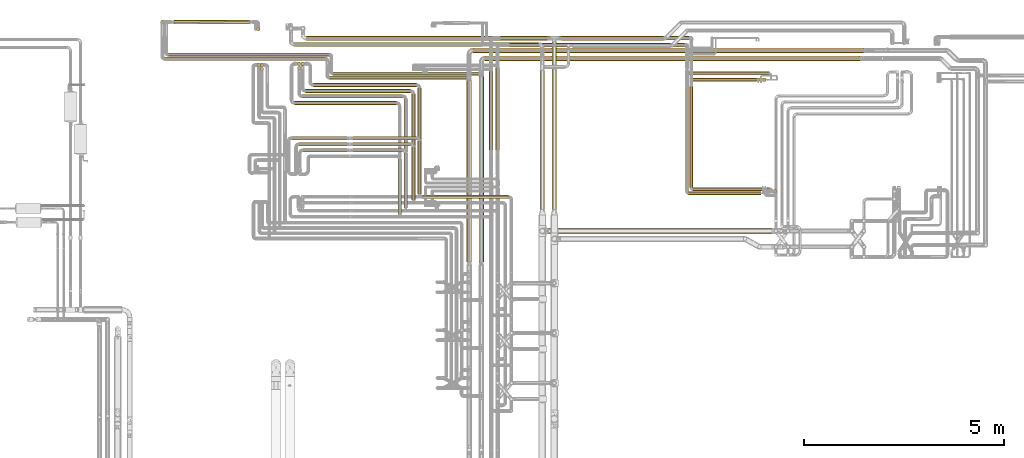
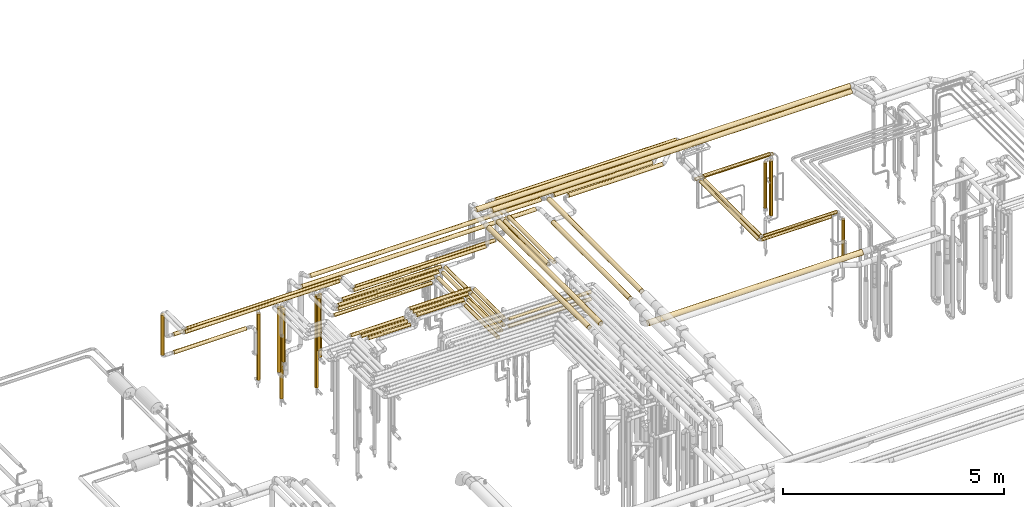
# One storey, part 6 of 824: 57 coverings.
"""IFC2X3 building model written with IfcOpenShell, lengths in millimetres."""

import ifcopenshell
import ifcopenshell.guid

model = None  # the IFC model being written
_history = None  # IfcOwnerHistory: only IFC2X3 demands one
_inside = {}  # id of a spatial element -> (the spatial element, [elements in it])
_under = {}  # id of a project, library or spatial element -> (it, [spatial elements below it])
_declared = {}  # id of a project -> (the project, [libraries it declares])
_typed = {}  # id of a type object -> (the type object, [elements of that type])
_made_of = {}  # id of a material, layer set ... -> (it, [elements and type objects made of it])


def new_model(schema):
    """Start an empty IFC model of exactly this schema.

    Asked for "IFC4X3", IfcOpenShell would pick the latest addendum, in which some entities
    have other attributes; the version numbers below select the first issue.
    IFC2X3 requires an IfcOwnerHistory on every rooted entity: one is made here for all.
    """
    global model, _history
    if schema == "IFC4X3":
        model = ifcopenshell.file(schema_version=(4, 3, 0, 0))
    else:
        model = ifcopenshell.file(schema=schema)
    _inside.clear()
    _under.clear()
    _declared.clear()
    _typed.clear()
    _made_of.clear()
    _history = None
    if model.schema == "IFC2X3":
        org = make("IfcOrganization", Name="unknown")
        user = make(
            "IfcPersonAndOrganization",
            ThePerson=make("IfcPerson", FamilyName="unknown"),
            TheOrganization=org,
        )
        app = make(
            "IfcApplication",
            ApplicationDeveloper=org,
            Version="unknown",
            ApplicationFullName="unknown",
            ApplicationIdentifier="unknown",
        )
        _history = make(
            "IfcOwnerHistory",
            OwningUser=user,
            OwningApplication=app,
            ChangeAction="ADDED",
            CreationDate=0,
        )
    return model


def make(cls, **values):
    """One entity of the class cls with the attributes given. An attribute that is None is left unset."""
    return model.create_entity(
        cls, **{name: value for name, value in values.items() if value is not None}
    )


def entity(cls, *values):
    """Any entity or typed value of the class cls, its attributes in the order of the schema. None: left unset."""
    e = model.create_entity(cls)
    for i, value in enumerate(values):
        if value is not None:
            e[i] = value
    return e


def rooted(cls, **values):
    """An entity with a GlobalId (a new one), such as an element, a storey or a relation."""
    return make(cls, GlobalId=ifcopenshell.guid.new(), OwnerHistory=_history, **values)


def si_unit(unit_type, name, prefix=None):
    """IfcSIUnit, for example si_unit("LENGTHUNIT", "METRE", prefix="MILLI")."""
    return make("IfcSIUnit", UnitType=unit_type, Prefix=prefix, Name=name)


def converted_unit(unit_type, name, factor, base, dimensions=None, offset=None):
    """IfcConversionBasedUnit, such as the inch: factor (a typed value) times the base unit."""
    return make(
        "IfcConversionBasedUnit"
        if offset is None
        else "IfcConversionBasedUnitWithOffset",
        ConversionOffset=offset,
        Dimensions=None
        if dimensions is None
        else entity("IfcDimensionalExponents", *dimensions),
        UnitType=unit_type,
        Name=name,
        ConversionFactor=make(
            "IfcMeasureWithUnit", ValueComponent=factor, UnitComponent=base
        ),
    )


def derived_unit(unit_type, elements):
    """IfcDerivedUnit: a product of units, each with its exponent."""
    return make(
        "IfcDerivedUnit",
        Elements=[
            make("IfcDerivedUnitElement", Unit=unit, Exponent=power)
            for unit, power in elements
        ],
        UnitType=unit_type,
    )


def assignment(units):
    """IfcUnitAssignment: the units of a project."""
    return None if units is None else make("IfcUnitAssignment", Units=units)


def point(xyz):
    """IfcCartesianPoint."""
    return None if xyz is None else make("IfcCartesianPoint", Coordinates=xyz)


def direction(xyz):
    """IfcDirection."""
    return None if xyz is None else make("IfcDirection", DirectionRatios=xyz)


def frame(location, z_axis=None, x_axis=None):
    """IfcAxis2Placement3D, a coordinate frame: its origin and axes. An axis left out is left unset."""
    return make(
        "IfcAxis2Placement3D",
        Location=point(location),
        Axis=direction(z_axis),
        RefDirection=direction(x_axis),
    )


def frame_2d(location, x_axis=None):
    """IfcAxis2Placement2D, a coordinate frame in the plane: its origin and x axis."""
    return make(
        "IfcAxis2Placement2D", Location=point(location), RefDirection=direction(x_axis)
    )


def origin():
    """The frame at (0, 0, 0) with its axes left unset."""
    return frame((0.0, 0.0, 0.0))


def origin_2d_with_axis():
    """The frame at (0, 0) in the plane with the x axis (1, 0) written out."""
    return frame_2d((0.0, 0.0), x_axis=(1.0, 0.0))


def place(relative_to, where):
    """IfcLocalPlacement: puts the frame where relative to a parent placement (None: the world)."""
    return make(
        "IfcLocalPlacement", PlacementRelTo=relative_to, RelativePlacement=where
    )


def context(
    kind, dimensions, precision=None, world=None, true_north=None, identifier=None
):
    """IfcGeometricRepresentationContext, for example the 3D "Model" context."""
    return make(
        "IfcGeometricRepresentationContext",
        ContextIdentifier=identifier,
        ContextType=kind,
        CoordinateSpaceDimension=dimensions,
        Precision=precision,
        WorldCoordinateSystem=world,
        TrueNorth=true_north,
    )


def subcontext(parent, identifier, kind, view, scale=None):
    """IfcGeometricRepresentationSubContext, for example "Body" below "Model"."""
    return make(
        "IfcGeometricRepresentationSubContext",
        ContextIdentifier=identifier,
        ContextType=kind,
        ParentContext=parent,
        TargetScale=scale,
        TargetView=view,
    )


def project(units=None, contexts=None):
    """IfcProject with its units and contexts."""
    return rooted(
        "IfcProject",
        Name="project",
        RepresentationContexts=contexts,
        UnitsInContext=assignment(units),
    )


def spatial(cls, under=None, at=None, **own):
    """A site, building, storey or space (cls), placed at a placement, below another one or the project."""
    s = rooted(cls, ObjectPlacement=at, **own)
    if under is not None:
        _under.setdefault(under.id(), (under, []))[1].append(s)
    return s


def polyline(points):
    """IfcPolyline through the points."""
    return make("IfcPolyline", Points=[point(p) for p in points])


def profile(cls, at=None, kind="AREA", **sizes):
    """A parametric profile (cls). Its sizes go by their IFC names, for example OverallWidth=200.0."""
    return make(cls, ProfileType=kind, Position=at, **sizes)


def circle(**sizes):
    """IfcCircleProfileDef."""
    return profile("IfcCircleProfileDef", **sizes)


def outline(outer, holes=None, kind="AREA"):
    """IfcArbitraryClosedProfileDef: a profile drawn as a closed curve; with holes, ...WithVoids."""
    if holes is None:
        return make("IfcArbitraryClosedProfileDef", ProfileType=kind, OuterCurve=outer)
    return make(
        "IfcArbitraryProfileDefWithVoids",
        ProfileType=kind,
        OuterCurve=outer,
        InnerCurves=holes,
    )


def extrude(swept, where, along, depth):
    """IfcExtrudedAreaSolid: the profile swept, set in the frame where, extruded along a direction by depth."""
    return make(
        "IfcExtrudedAreaSolid",
        SweptArea=swept,
        Position=where,
        ExtrudedDirection=direction(along),
        Depth=depth,
    )


def shape(context_of_items, identifier, shape_type, items):
    """IfcShapeRepresentation: the items that make up one representation, for example the "Body"."""
    return make(
        "IfcShapeRepresentation",
        ContextOfItems=context_of_items,
        RepresentationIdentifier=identifier,
        RepresentationType=shape_type,
        Items=items,
    )


def made_of(thing, what):
    """Note that an element or type object is made of a material, layer set ...; save() writes the relation."""
    if what is not None:
        _made_of.setdefault(what.id(), (what, []))[1].append(thing)
    return thing


def element(
    cls,
    number,
    at=None,
    inside=None,
    cuts=None,
    type_object=None,
    material=None,
    context=None,
    identifier="Body",
    shape_type=None,
    held_by="IfcProductDefinitionShape",
    body=None,
    shapes=None,
    **own,
):
    """One element of the class cls, such as IfcWall. Its Tag is "e" and its number.

    at: its placement. inside: the storey or other place that contains it. cuts: it is an
    opening in that element (IfcRelVoidsElement). A single representation is given by context,
    identifier, shape_type and body (its items); several are given by shapes. held_by: the class
    of the entity that holds the representations. save() writes the other relations.
    """
    e = rooted(cls, Tag="e%d" % number, ObjectPlacement=at, **own)
    if body is not None:
        shapes = [shape(context, identifier, shape_type, body)]
    if shapes is not None:
        e.Representation = make(held_by, Representations=shapes)
    if inside is not None:
        _inside.setdefault(inside.id(), (inside, []))[1].append(e)
    if cuts is not None:
        rooted(
            "IfcRelVoidsElement", RelatingBuildingElement=cuts, RelatedOpeningElement=e
        )
    if type_object is not None:
        _typed.setdefault(type_object.id(), (type_object, []))[1].append(e)
    return made_of(e, material)


def aggregate(whole, parts):
    """IfcRelAggregates: a whole, such as a stair, and the parts it consists of."""
    return rooted("IfcRelAggregates", RelatingObject=whole, RelatedObjects=parts)


def save(model, path):
    """Write the relations noted so far, then the file.

    IfcRelAggregates (storeys below a building ...), IfcRelContainedInSpatialStructure (elements
    in a storey), IfcRelDefinesByType, IfcRelAssociatesMaterial and IfcRelDeclares: one each for
    every whole, place, type object, material and project.
    """
    for whole, parts in _under.values():
        aggregate(whole, parts)
    for where, things in _inside.values():
        rooted(
            "IfcRelContainedInSpatialStructure",
            RelatedElements=things,
            RelatingStructure=where,
        )
    for kind, things in _typed.values():
        rooted("IfcRelDefinesByType", RelatedObjects=things, RelatingType=kind)
    for what, things in _made_of.values():
        rooted("IfcRelAssociatesMaterial", RelatedObjects=things, RelatingMaterial=what)
    for by, libraries in _declared.values():
        rooted("IfcRelDeclares", RelatingContext=by, RelatedDefinitions=libraries)
    model.write(path)


model = new_model("IFC2X3")

# Units and contexts
model_context = context("Model", 3, precision=0.01, world=origin(), true_north=direction((6.12303176911189e-17, 1.0)))
body_context = subcontext(model_context, "Body", "Model", "MODEL_VIEW")
ifc_project = project(units=[si_unit("LENGTHUNIT", "METRE", prefix="MILLI"), si_unit("AREAUNIT", "SQUARE_METRE"), si_unit("VOLUMEUNIT", "CUBIC_METRE"), converted_unit("PLANEANGLEUNIT", "DEGREE", entity("IfcRatioMeasure", 0.0174532925199433), si_unit("PLANEANGLEUNIT", "RADIAN"), dimensions=[0, 0, 0, 0, 0, 0, 0]), si_unit("MASSUNIT", "GRAM", prefix="KILO"), derived_unit("MASSDENSITYUNIT", [(si_unit("MASSUNIT", "GRAM", prefix="KILO"), 1), (si_unit("LENGTHUNIT", "METRE"), -3)]), derived_unit("MOMENTOFINERTIAUNIT", [(si_unit("LENGTHUNIT", "METRE"), 4)]), si_unit("TIMEUNIT", "SECOND"), si_unit("FREQUENCYUNIT", "HERTZ"), si_unit("THERMODYNAMICTEMPERATUREUNIT", "DEGREE_CELSIUS"), derived_unit("THERMALTRANSMITTANCEUNIT", [(si_unit("MASSUNIT", "GRAM", prefix="KILO"), 1), (si_unit("THERMODYNAMICTEMPERATUREUNIT", "KELVIN"), -1), (si_unit("TIMEUNIT", "SECOND"), -3)]), derived_unit("VOLUMETRICFLOWRATEUNIT", [(si_unit("LENGTHUNIT", "METRE"), 3), (si_unit("TIMEUNIT", "SECOND"), -1)]), derived_unit("MASSFLOWRATEUNIT", [(si_unit("MASSUNIT", "GRAM", prefix="KILO"), 1), (si_unit("TIMEUNIT", "SECOND"), -1)]), derived_unit("ROTATIONALFREQUENCYUNIT", [(si_unit("TIMEUNIT", "SECOND"), -1)]), si_unit("ELECTRICCURRENTUNIT", "AMPERE"), si_unit("ELECTRICVOLTAGEUNIT", "VOLT"), si_unit("POWERUNIT", "WATT"), si_unit("FORCEUNIT", "NEWTON", prefix="KILO"), si_unit("ILLUMINANCEUNIT", "LUX"), si_unit("LUMINOUSFLUXUNIT", "LUMEN"), si_unit("LUMINOUSINTENSITYUNIT", "CANDELA"), derived_unit("USERDEFINED", [(si_unit("MASSUNIT", "GRAM", prefix="KILO"), -1), (si_unit("LENGTHUNIT", "METRE"), -2), (si_unit("TIMEUNIT", "SECOND"), 3), (si_unit("LUMINOUSFLUXUNIT", "LUMEN"), 1)]), derived_unit("LINEARVELOCITYUNIT", [(si_unit("LENGTHUNIT", "METRE"), 1), (si_unit("TIMEUNIT", "SECOND"), -1)]), si_unit("PRESSUREUNIT", "PASCAL"), derived_unit("USERDEFINED", [(si_unit("LENGTHUNIT", "METRE"), -2), (si_unit("MASSUNIT", "GRAM", prefix="KILO"), 1), (si_unit("TIMEUNIT", "SECOND"), -2)]), derived_unit("LINEARFORCEUNIT", [(si_unit("MASSUNIT", "GRAM", prefix="KILO"), 1), (si_unit("LENGTHUNIT", "METRE"), 1), (si_unit("TIMEUNIT", "SECOND"), -2), (si_unit("LENGTHUNIT", "METRE"), -1)]), derived_unit("PLANARFORCEUNIT", [(si_unit("MASSUNIT", "GRAM", prefix="KILO"), 1), (si_unit("LENGTHUNIT", "METRE"), 1), (si_unit("TIMEUNIT", "SECOND"), -2), (si_unit("LENGTHUNIT", "METRE"), -2)])], contexts=[model_context])

# Site, building, storey
site_placement = place(None, origin())
site = spatial("IfcSite", under=ifc_project, at=site_placement, CompositionType="ELEMENT")
building_placement = place(site_placement, origin())
building = spatial("IfcBuilding", under=site, at=building_placement, CompositionType="ELEMENT")
storey_placement = place(building_placement, frame((0.0, 0.0, 28200.0)))
storey = spatial("IfcBuildingStorey", under=building, at=storey_placement, CompositionType="ELEMENT", Elevation=28200.0)

# Coverings
covering_1_placement = place(storey_placement, frame((36012.93, 18744.53, 3485.65)))
element("IfcCovering", 1, at=covering_1_placement, inside=storey, PredefinedType="INSULATION", context=body_context, shape_type="SweptSolid", body=[
    extrude(outline(polyline([(-8.19, -62.21), (8.19, -62.21), (24.01, -57.97), (38.2, -49.78), (49.78, -38.2), (57.97, -24.01), (62.21, -8.19), (62.21, 8.19), (57.97, 24.01), (49.78, 38.2), (38.2, 49.78), (24.01, 57.97), (8.19, 62.21), (-8.19, 62.21), (-24.01, 57.97), (-38.2, 49.78), (-49.78, 38.2), (-57.97, 24.01), (-62.21, 8.19), (-62.21, -8.19), (-57.97, -24.01), (-49.78, -38.2), (-38.2, -49.78), (-24.01, -57.97), (-8.19, -62.21)])), frame((0.0, 64.39, 64.35), z_axis=(1.0, -4.85826303863744e-06, 0.0), x_axis=(6.34811881532513e-07, 0.130526192218576, -0.991444861373802)), (0.0, 0.0, 1.0), 9771.5320502305),
])
covering_2_placement = place(storey_placement, frame((28192.29, 19468.46, 1848.0)))
element("IfcCovering", 2, at=covering_2_placement, inside=storey, PredefinedType="INSULATION", context=body_context, shape_type="SweptSolid", body=[
    extrude(circle(Radius=46.15, at=origin_2d_with_axis()), frame((47.75, 47.75, 0.0)), (0.0, 0.0, 1.0), 1103.5044787345),
])
covering_3_placement = place(storey_placement, frame((28288.03, 18549.76, 2951.76)))
element("IfcCovering", 3, at=covering_3_placement, inside=storey, PredefinedType="INSULATION", context=body_context, shape_type="SweptSolid", body=[
    extrude(circle(Radius=46.15, at=origin_2d_with_axis()), frame((0.0, 47.75, 47.75), z_axis=(1.0, 0.0, 0.0), x_axis=(0.0, 1.0, 0.0)), (0.0, 0.0, 1.0), 4034.00000000001),
])
covering_4_placement = place(storey_placement, frame((32418.03, 18077.16, 2951.76)))
element("IfcCovering", 4, at=covering_4_placement, inside=storey, PredefinedType="INSULATION", context=body_context, shape_type="SweptSolid", body=[
    extrude(circle(Radius=46.15, at=origin_2d_with_axis()), frame((0.0, 47.75, 47.75), z_axis=(1.0, -2.64804923458862e-08, -1.57061026051097e-07), x_axis=(2.64804923458866e-08, 1.0, 0.0)), (0.0, 0.0, 1.0), 3452.34056165486),
])
covering_5_placement = place(storey_placement, frame((35853.75, 13506.7, 3485.65)))
element("IfcCovering", 5, at=covering_5_placement, inside=storey, PredefinedType="INSULATION", context=body_context, shape_type="SweptSolid", body=[
    extrude(circle(Radius=62.75, at=origin_2d_with_axis()), frame((64.35, 0.0, 64.35), z_axis=(0.0, 1.0, -9.47129949639456e-08), x_axis=(-1.0, 0.0, 0.0)), (0.0, 0.0, 1.0), 4542.20661769209),
])
covering_6_placement = place(storey_placement, frame((28529.16, 19465.54, 1749.4)))
element("IfcCovering", 6, at=covering_6_placement, inside=storey, PredefinedType="INSULATION", context=body_context, shape_type="SweptSolid", body=[
    extrude(circle(Radius=49.0, at=origin_2d_with_axis()), frame((0.06, 50.6, 50.6), z_axis=(0.999999363543567, 0.00112823422292339, 0.0), x_axis=(-0.00112823422292339, 0.999999363543567, 0.0)), (0.0, 0.0, 1.0), 1888.98967089916),
])
covering_7_placement = place(storey_placement, frame((30594.46, 19295.69, 423.0)))
element("IfcCovering", 7, at=covering_7_placement, inside=storey, PredefinedType="INSULATION", context=body_context, shape_type="SweptSolid", body=[
    extrude(circle(Radius=46.15, at=origin_2d_with_axis()), frame((47.75, 47.75, 0.0)), (0.0, 0.0, 1.0), 1829.00000000023),
])
covering_8_placement = place(storey_placement, frame((36315.03, 18542.35, 3485.65)))
element("IfcCovering", 8, at=covering_8_placement, inside=storey, PredefinedType="INSULATION", context=body_context, shape_type="SweptSolid", body=[
    extrude(circle(Radius=62.75, at=origin_2d_with_axis()), frame((0.0, 64.35, 64.35), z_axis=(1.0, 0.0, 0.0), x_axis=(0.0, -1.0, 0.0)), (0.0, 0.0, 1.0), 9389.4356787662),
])
covering_9_placement = place(storey_placement, frame((36155.69, 13506.7, 3485.65)))
element("IfcCovering", 9, at=covering_9_placement, inside=storey, PredefinedType="INSULATION", context=body_context, shape_type="SweptSolid", body=[
    extrude(circle(Radius=62.75, at=origin_2d_with_axis()), frame((64.35, 0.0, 64.35), z_axis=(0.0, 1.0, 0.0), x_axis=(1.0, 0.0, 0.0)), (0.0, 0.0, 1.0), 4642.2472086319),
])
covering_10_placement = place(storey_placement, frame((28388.03, 18652.26, 2952.16)))
element("IfcCovering", 10, at=covering_10_placement, inside=storey, PredefinedType="INSULATION", context=body_context, shape_type="SweptSolid", body=[
    extrude(circle(Radius=46.15, at=origin_2d_with_axis()), frame((0.0, 47.75, 47.75), z_axis=(1.0, 0.0, 0.0), x_axis=(0.0, 1.0, 0.0)), (0.0, 0.0, 1.0), 4031.49999999999),
])
covering_11_placement = place(storey_placement, frame((32515.53, 18177.2, 2952.42)))
element("IfcCovering", 11, at=covering_11_placement, inside=storey, PredefinedType="INSULATION", context=body_context, shape_type="SweptSolid", body=[
    extrude(circle(Radius=46.15, at=origin_2d_with_axis()), frame((0.0, 47.75, 47.75), z_axis=(1.0, 0.0, 0.0), x_axis=(0.0, 1.0, 0.0)), (0.0, 0.0, 1.0), 3656.50789865934),
])
covering_12_placement = place(storey_placement, frame((28524.22, 19465.61, 2249.4)))
element("IfcCovering", 12, at=covering_12_placement, inside=storey, PredefinedType="INSULATION", context=body_context, shape_type="SweptSolid", body=[
    extrude(circle(Radius=49.0, at=origin_2d_with_axis()), frame((0.0, 50.6, 50.6), z_axis=(1.0, 0.0, 0.0), x_axis=(0.0, -1.0, 0.0)), (0.0, 0.0, 1.0), 1893.98090500761),
])
covering_13_placement = place(storey_placement, frame((30677.33, 18293.46, 1500.5)))
element("IfcCovering", 13, at=covering_13_placement, inside=storey, PredefinedType="INSULATION", context=body_context, shape_type="SweptSolid", body=[
    extrude(circle(Radius=46.15, at=origin_2d_with_axis()), frame((47.75, 47.75, 0.0), z_axis=(0.0, 0.0, 1.0), x_axis=(0.0, -1.0, 0.0)), (0.0, 0.0, 1.0), 1451.5),
])
covering_14_placement = place(storey_placement, frame((30677.33, 18393.46, 423.0)))
element("IfcCovering", 14, at=covering_14_placement, inside=storey, PredefinedType="INSULATION", context=body_context, shape_type="SweptSolid", body=[
    extrude(circle(Radius=46.15, at=origin_2d_with_axis()), frame((47.75, 47.75, 0.0), z_axis=(0.0, 0.0, 1.0), x_axis=(0.0, -1.0, 0.0)), (0.0, 0.0, 1.0), 2529.00000000008),
])
covering_15_placement = place(storey_placement, frame((30609.3, 18393.46, 1178.45)))
element("IfcCovering", 15, at=covering_15_placement, inside=storey, PredefinedType="INSULATION", context=body_context, shape_type="SweptSolid", body=[
    extrude(circle(Radius=46.15, at=origin_2d_with_axis()), frame((47.75, 47.75, 0.0), z_axis=(0.0, 0.0, 1.0), x_axis=(0.0, 1.0, 0.0)), (0.0, 0.0, 1.0), 1773.55173999997),
])
covering_16_placement = place(storey_placement, frame((38500.22, 18877.0, 2945.65)))
element("IfcCovering", 16, at=covering_16_placement, inside=storey, PredefinedType="INSULATION", context=body_context, shape_type="SweptSolid", body=[
    extrude(circle(Radius=52.75, at=origin_2d_with_axis()), frame((0.0, 54.35, 54.35), z_axis=(1.0, 0.0, 0.0), x_axis=(0.0, -1.0, 0.0)), (0.0, 0.0, 1.0), 2456.78207897576),
])
covering_17_placement = place(storey_placement, frame((31545.66, 17444.61, 2953.4)))
element("IfcCovering", 17, at=covering_17_placement, inside=storey, PredefinedType="INSULATION", context=body_context, shape_type="SweptSolid", body=[
    extrude(circle(Radius=45.0, at=origin_2d_with_axis()), frame((0.0, 46.6, 46.6), z_axis=(1.0, 0.0, 0.0), x_axis=(0.0, 1.0, 0.0)), (0.0, 0.0, 1.0), 2553.37052000001),
])
covering_18_placement = place(storey_placement, frame((31615.07, 18424.61, 379.5)))
element("IfcCovering", 18, at=covering_18_placement, inside=storey, PredefinedType="INSULATION", context=body_context, shape_type="SweptSolid", body=[
    extrude(circle(Radius=45.0, at=origin_2d_with_axis()), frame((46.6, 46.6, 0.0), z_axis=(0.0, 0.0, 1.0), x_axis=(0.0, 1.0, 0.0)), (0.0, 0.0, 1.0), 2544.50000000013),
])
covering_19_placement = place(storey_placement, frame((31550.41, 18902.64, 2845.49)))
element("IfcCovering", 19, at=covering_19_placement, inside=storey, PredefinedType="INSULATION", context=body_context, shape_type="SweptSolid", body=[
    extrude(circle(Radius=53.0, at=origin_2d_with_axis()), frame((0.0, 54.6, 54.6), z_axis=(1.0, 0.0, 0.0), x_axis=(0.0, -1.0, 0.0)), (0.0, 0.0, 1.0), 6102.89199936658),
])
covering_20_placement = place(storey_placement, frame((31737.66, 17613.61, 2953.4)))
element("IfcCovering", 20, at=covering_20_placement, inside=storey, PredefinedType="INSULATION", context=body_context, shape_type="SweptSolid", body=[
    extrude(circle(Radius=45.0, at=origin_2d_with_axis()), frame((0.0, 46.6, 46.6), z_axis=(1.0, 0.0, 0.0), x_axis=(0.0, 1.0, 0.0)), (0.0, 0.0, 1.0), 2513.00001774619),
])
covering_21_placement = place(storey_placement, frame((34280.07, 14866.0, 2953.4)))
element("IfcCovering", 21, at=covering_21_placement, inside=storey, PredefinedType="INSULATION", context=body_context, shape_type="SweptSolid", body=[
    extrude(circle(Radius=45.0, at=origin_2d_with_axis()), frame((46.6, 0.0, 46.6), z_axis=(0.0, 1.0, 0.0), x_axis=(1.0, 0.0, 0.0)), (0.0, 0.0, 1.0), 2718.20272594582),
])
covering_22_placement = place(storey_placement, frame((34128.44, 14716.0, 3153.4)))
element("IfcCovering", 22, at=covering_22_placement, inside=storey, PredefinedType="INSULATION", context=body_context, shape_type="SweptSolid", body=[
    extrude(circle(Radius=45.0, at=origin_2d_with_axis()), frame((46.6, 0.0, 46.6), z_axis=(0.0, 1.0, 0.0), x_axis=(1.0, 0.0, 0.0)), (0.0, 0.0, 1.0), 1369.20291694587),
])
covering_23_placement = place(storey_placement, frame((34280.07, 14866.0, 3153.4)))
element("IfcCovering", 23, at=covering_23_placement, inside=storey, PredefinedType="INSULATION", context=body_context, shape_type="SweptSolid", body=[
    extrude(circle(Radius=45.0, at=origin_2d_with_axis()), frame((46.6, 0.0, 46.6), z_axis=(0.0, 1.0, 0.0), x_axis=(-1.0, 0.0, 0.0)), (0.0, 0.0, 1.0), 1369.20271676073),
])
covering_24_placement = place(storey_placement, frame((33011.03, 16264.61, 3153.4)))
element("IfcCovering", 24, at=covering_24_placement, inside=storey, PredefinedType="INSULATION", context=body_context, shape_type="SweptSolid", body=[
    extrude(circle(Radius=45.0, at=origin_2d_with_axis()), frame((0.0, 46.6, 46.6), z_axis=(1.0, 0.0, 0.0), x_axis=(0.0, -1.0, 0.0)), (0.0, 0.0, 1.0), 1239.62947996842),
])
covering_25_placement = place(storey_placement, frame((31756.25, 16264.61, 2953.4)))
element("IfcCovering", 25, at=covering_25_placement, inside=storey, PredefinedType="INSULATION", context=body_context, shape_type="SweptSolid", body=[
    extrude(circle(Radius=45.0, at=origin_2d_with_axis()), frame((0.0, 46.6, 46.6), z_axis=(1.0, 0.0, 0.0), x_axis=(0.0, -1.0, 0.0)), (0.0, 0.0, 1.0), 1102.78000899999),
])
covering_26_placement = place(storey_placement, frame((31615.07, 18320.35, 1469.5)))
element("IfcCovering", 26, at=covering_26_placement, inside=storey, PredefinedType="INSULATION", context=body_context, shape_type="SweptSolid", body=[
    extrude(circle(Radius=45.0, at=origin_2d_with_axis()), frame((46.6, 46.6, 0.0), z_axis=(0.0, 0.0, 1.0), x_axis=(0.0, 1.0, 0.0)), (0.0, 0.0, 1.0), 1454.50000000077),
])
covering_27_placement = place(storey_placement, frame((37687.2, 14827.72, 2838.86)))
element("IfcCovering", 27, at=covering_27_placement, inside=storey, PredefinedType="INSULATION", context=body_context, shape_type="SweptSolid", body=[
    extrude(circle(Radius=59.5, at=origin_2d_with_axis()), frame((61.1, 0.0, 61.1), z_axis=(0.0, 1.0, 3.91458551998914e-05), x_axis=(-1.0, 0.0, 0.0)), (0.0, 0.0, 1.0), 3480.66550139349),
])
covering_28_placement = place(storey_placement, frame((43259.74, 18027.89, 1297.88)))
element("IfcCovering", 28, at=covering_28_placement, inside=storey, PredefinedType="INSULATION", context=body_context, shape_type="SweptSolid", body=[
    extrude(circle(Radius=41.75, at=origin_2d_with_axis()), frame((43.35, 43.35, 0.0), z_axis=(0.0, 0.0, 1.0), x_axis=(0.0, -1.0, 0.0)), (0.0, 0.0, 1.0), 1514.12352106977),
])
covering_29_placement = place(storey_placement, frame((43109.74, 18027.59, 1557.25)))
element("IfcCovering", 29, at=covering_29_placement, inside=storey, PredefinedType="INSULATION", context=body_context, shape_type="SweptSolid", body=[
    extrude(circle(Radius=41.75, at=origin_2d_with_axis()), frame((43.35, 43.35, 0.0), z_axis=(0.0, 0.0, 1.0), x_axis=(0.0, -1.0, 0.0)), (0.0, 0.0, 1.0), 1254.75207132545),
])
covering_30_placement = place(storey_placement, frame((43532.87, 15237.98, 1737.28)))
element("IfcCovering", 30, at=covering_30_placement, inside=storey, PredefinedType="INSULATION", context=body_context, shape_type="SweptSolid", body=[
    extrude(circle(Radius=41.75, at=origin_2d_with_axis()), frame((43.35, 43.35, 0.0), z_axis=(0.0, 0.0, 1.0), x_axis=(0.0, 1.0, 0.0)), (0.0, 0.0, 1.0), 1046.92285172848),
])
covering_31_placement = place(storey_placement, frame((36697.02, 19064.89, 3349.3)))
element("IfcCovering", 31, at=covering_31_placement, inside=storey, PredefinedType="INSULATION", context=body_context, shape_type="SweptSolid", body=[
    extrude(circle(Radius=49.0, at=origin_2d_with_axis()), frame((0.0, 50.6, 50.6), z_axis=(1.0, 0.0, 0.0), x_axis=(0.0, -1.0, 0.0)), (0.0, 0.0, 1.0), 4722.19367836544),
])
covering_32_placement = place(storey_placement, frame((36418.12, 16315.93, 3349.3)))
element("IfcCovering", 32, at=covering_32_placement, inside=storey, PredefinedType="INSULATION", context=body_context, shape_type="SweptSolid", body=[
    extrude(circle(Radius=49.0, at=origin_2d_with_axis()), frame((50.6, 0.0, 50.6), z_axis=(0.0, 1.0, 0.0), x_axis=(1.0, 0.0, 0.0)), (0.0, 0.0, 1.0), 1961.97743456359),
])
covering_33_placement = place(storey_placement, frame((36922.02, 18885.81, 3349.3)))
element("IfcCovering", 33, at=covering_33_placement, inside=storey, PredefinedType="INSULATION", context=body_context, shape_type="SweptSolid", body=[
    extrude(circle(Radius=49.0, at=origin_2d_with_axis()), frame((0.0, 50.6, 50.6), z_axis=(1.0, 1.42382432847069e-05, 0.0), x_axis=(1.42382432847069e-05, -1.0, 0.0)), (0.0, 0.0, 1.0), 4390.35001608479),
])
covering_34_placement = place(storey_placement, frame((36579.05, 16312.49, 3349.3)))
element("IfcCovering", 34, at=covering_34_placement, inside=storey, PredefinedType="INSULATION", context=body_context, shape_type="SweptSolid", body=[
    extrude(circle(Radius=49.0, at=origin_2d_with_axis()), frame((50.6, 0.0, 50.6), z_axis=(0.0, 1.0, 0.0), x_axis=(1.0, 0.0, 0.0)), (0.0, 0.0, 1.0), 2065.41871271011),
])
covering_35_placement = place(storey_placement, frame((37987.2, 14827.72, 2938.9)))
element("IfcCovering", 35, at=covering_35_placement, inside=storey, PredefinedType="INSULATION", context=body_context, shape_type="SweptSolid", body=[
    extrude(circle(Radius=59.5, at=origin_2d_with_axis()), frame((61.1, 0.0, 61.1), z_axis=(0.0, 1.0, 0.0), x_axis=(1.0, 0.0, 0.0)), (0.0, 0.0, 1.0), 4193.99999999999),
])
covering_36_placement = place(storey_placement, frame((38223.3, 19053.12, 2945.4)))
element("IfcCovering", 36, at=covering_36_placement, inside=storey, PredefinedType="INSULATION", context=body_context, shape_type="SweptSolid", body=[
    extrude(circle(Radius=53.0, at=origin_2d_with_axis()), frame((0.0, 54.6, 54.6), z_axis=(1.0, 0.0, 0.0), x_axis=(0.0, -1.0, 0.0)), (0.0, 0.0, 1.0), 2563.05314198827),
])
covering_37_placement = place(storey_placement, frame((31702.07, 18424.61, 1196.13)))
element("IfcCovering", 37, at=covering_37_placement, inside=storey, PredefinedType="INSULATION", context=body_context, shape_type="SweptSolid", body=[
    extrude(circle(Radius=45.0, at=origin_2d_with_axis()), frame((46.6, 46.6, 0.0), z_axis=(0.0, 0.0, 1.0), x_axis=(0.0, -1.0, 0.0)), (0.0, 0.0, 1.0), 1727.87245965627),
])
covering_38_placement = place(storey_placement, frame((32016.66, 17894.61, 2953.4)))
element("IfcCovering", 38, at=covering_38_placement, inside=storey, PredefinedType="INSULATION", context=body_context, shape_type="SweptSolid", body=[
    extrude(circle(Radius=45.0, at=origin_2d_with_axis()), frame((0.0, 46.6, 46.6), z_axis=(1.0, 0.0, 0.0), x_axis=(0.0, 1.0, 0.0)), (0.0, 0.0, 1.0), 2582.37054110707),
])
covering_39_placement = place(storey_placement, frame((34628.44, 15215.0, 2953.4)))
element("IfcCovering", 39, at=covering_39_placement, inside=storey, PredefinedType="INSULATION", context=body_context, shape_type="SweptSolid", body=[
    extrude(circle(Radius=45.0, at=origin_2d_with_axis()), frame((46.6, 0.0, 46.6), z_axis=(0.0, 1.0, 0.0), x_axis=(1.0, 0.0, 0.0)), (0.0, 0.0, 1.0), 2650.20251676074),
])
covering_40_placement = place(storey_placement, frame((34751.03, 15092.41, 2953.4)))
element("IfcCovering", 40, at=covering_40_placement, inside=storey, PredefinedType="INSULATION", context=body_context, shape_type="SweptSolid", body=[
    extrude(circle(Radius=45.0, at=origin_2d_with_axis()), frame((0.0, 46.6, 46.6), z_axis=(1.0, 0.0, 0.0), x_axis=(0.0, 1.0, 0.0)), (0.0, 0.0, 1.0), 2148.00000000003),
])
covering_41_placement = place(storey_placement, frame((31824.66, 17744.61, 2953.4)))
element("IfcCovering", 41, at=covering_41_placement, inside=storey, PredefinedType="INSULATION", context=body_context, shape_type="SweptSolid", body=[
    extrude(circle(Radius=45.0, at=origin_2d_with_axis()), frame((0.0, 46.6, 46.6), z_axis=(1.0, 0.0, 0.0), x_axis=(0.0, 1.0, 0.0)), (0.0, 0.0, 1.0), 2624.3705410775),
])
covering_42_placement = place(storey_placement, frame((34478.44, 15065.0, 2953.4)))
element("IfcCovering", 42, at=covering_42_placement, inside=storey, PredefinedType="INSULATION", context=body_context, shape_type="SweptSolid", body=[
    extrude(circle(Radius=45.0, at=origin_2d_with_axis()), frame((46.6, 0.0, 46.6), z_axis=(0.0, 1.0, 0.0), x_axis=(1.0, 0.0, 0.0)), (0.0, 0.0, 1.0), 2650.20271676073),
])
covering_43_placement = place(storey_placement, frame((34751.03, 15092.41, 3153.4)))
element("IfcCovering", 43, at=covering_43_placement, inside=storey, PredefinedType="INSULATION", context=body_context, shape_type="SweptSolid", body=[
    extrude(circle(Radius=45.0, at=origin_2d_with_axis()), frame((0.0, 46.6, 46.6), z_axis=(1.0, 0.0, 0.0), x_axis=(0.0, 1.0, 0.0)), (0.0, 0.0, 1.0), 2148.00000000005),
])
covering_44_placement = place(storey_placement, frame((34628.44, 15215.0, 3153.4)))
element("IfcCovering", 44, at=covering_44_placement, inside=storey, PredefinedType="INSULATION", context=body_context, shape_type="SweptSolid", body=[
    extrude(circle(Radius=45.0, at=origin_2d_with_axis()), frame((46.6, 0.0, 46.6), z_axis=(0.0, 1.0, 0.0), x_axis=(-1.0, 0.0, 0.0)), (0.0, 0.0, 1.0), 1320.20250776075),
])
covering_45_placement = place(storey_placement, frame((34478.44, 15065.0, 3153.4)))
element("IfcCovering", 45, at=covering_45_placement, inside=storey, PredefinedType="INSULATION", context=body_context, shape_type="SweptSolid", body=[
    extrude(circle(Radius=45.0, at=origin_2d_with_axis()), frame((46.6, 0.0, 46.6), z_axis=(0.0, 1.0, 0.0), x_axis=(-1.0, 0.0, 0.0)), (0.0, 0.0, 1.0), 1320.20271676074),
])
covering_46_placement = place(storey_placement, frame((33011.03, 16414.61, 3153.4)))
element("IfcCovering", 46, at=covering_46_placement, inside=storey, PredefinedType="INSULATION", context=body_context, shape_type="SweptSolid", body=[
    extrude(circle(Radius=45.0, at=origin_2d_with_axis()), frame((0.0, 46.6, 46.6), z_axis=(1.0, 0.0, 0.0), x_axis=(0.0, -1.0, 0.0)), (0.0, 0.0, 1.0), 1437.99999100004),
])
covering_47_placement = place(storey_placement, frame((33011.03, 16564.61, 3153.4)))
element("IfcCovering", 47, at=covering_47_placement, inside=storey, PredefinedType="INSULATION", context=body_context, shape_type="SweptSolid", body=[
    extrude(circle(Radius=45.0, at=origin_2d_with_axis()), frame((0.0, 46.6, 46.6), z_axis=(1.0, 0.0, 0.0), x_axis=(0.0, -1.0, 0.0)), (0.0, 0.0, 1.0), 1587.99999100001),
])
covering_48_placement = place(storey_placement, frame((31660.25, 16414.61, 2953.4)))
element("IfcCovering", 48, at=covering_48_placement, inside=storey, PredefinedType="INSULATION", context=body_context, shape_type="SweptSolid", body=[
    extrude(circle(Radius=45.0, at=origin_2d_with_axis()), frame((0.0, 46.6, 46.6), z_axis=(1.0, 0.0, 0.0), x_axis=(0.0, -1.0, 0.0)), (0.0, 0.0, 1.0), 1198.77996899999),
])
covering_49_placement = place(storey_placement, frame((31471.03, 16564.61, 2953.4)))
element("IfcCovering", 49, at=covering_49_placement, inside=storey, PredefinedType="INSULATION", context=body_context, shape_type="SweptSolid", body=[
    extrude(circle(Radius=45.0, at=origin_2d_with_axis()), frame((0.0, 46.6, 46.6), z_axis=(1.0, 0.0, 0.0), x_axis=(0.0, -1.0, 0.0)), (0.0, 0.0, 1.0), 1388.00000000001),
])
covering_50_placement = place(storey_placement, frame((31850.7, 19053.12, 2945.4)))
element("IfcCovering", 50, at=covering_50_placement, inside=storey, PredefinedType="INSULATION", context=body_context, shape_type="SweptSolid", body=[
    extrude(circle(Radius=53.0, at=origin_2d_with_axis()), frame((0.0, 54.6, 54.6), z_axis=(1.0, 0.0, 0.0), x_axis=(0.0, 1.0, 0.0)), (0.0, 0.0, 1.0), 6022.59656958631),
])
covering_51_placement = place(storey_placement, frame((37900.3, 14213.02, 2426.4)))
element("IfcCovering", 51, at=covering_51_placement, inside=storey, PredefinedType="INSULATION", context=body_context, shape_type="SweptSolid", body=[
    extrude(circle(Radius=72.0, at=origin_2d_with_axis()), frame((0.0, 73.6, 73.6), z_axis=(1.0, 0.0, 0.0), x_axis=(0.0, -1.0, 0.0)), (0.0, 0.0, 1.0), 5589.73431158422),
])
covering_52_placement = place(storey_placement, frame((41524.22, 18027.89, 2956.65)))
element("IfcCovering", 52, at=covering_52_placement, inside=storey, PredefinedType="INSULATION", context=body_context, shape_type="SweptSolid", body=[
    extrude(circle(Radius=41.75, at=origin_2d_with_axis()), frame((0.0, 43.35, 43.35), z_axis=(1.0, 0.0, 0.0), x_axis=(0.0, -1.0, 0.0)), (0.0, 0.0, 1.0), 1740.87191154267),
])
covering_53_placement = place(storey_placement, frame((41407.37, 18187.59, 2806.65)))
element("IfcCovering", 53, at=covering_53_placement, inside=storey, PredefinedType="INSULATION", context=body_context, shape_type="SweptSolid", body=[
    extrude(circle(Radius=41.75, at=origin_2d_with_axis()), frame((0.0, 43.35, 43.35), z_axis=(1.0, 0.0, 0.0), x_axis=(0.0, 1.0, 0.0)), (0.0, 0.0, 1.0), 2027.71557427449),
])
covering_54_placement = place(storey_placement, frame((41514.22, 15288.97, 2956.66)))
element("IfcCovering", 54, at=covering_54_placement, inside=storey, PredefinedType="INSULATION", context=body_context, shape_type="SweptSolid", body=[
    extrude(circle(Radius=41.75, at=origin_2d_with_axis()), frame((0.0, 43.34, 43.34), z_axis=(1.0, 0.0, 0.0), x_axis=(0.0, 0.961261695938307, -0.275637355817041)), (0.0, 0.0, 1.0), 1924.0),
])
covering_55_placement = place(storey_placement, frame((41407.37, 15189.49, 2956.65)))
element("IfcCovering", 55, at=covering_55_placement, inside=storey, PredefinedType="INSULATION", context=body_context, shape_type="SweptSolid", body=[
    extrude(circle(Radius=41.75, at=origin_2d_with_axis()), frame((0.0, 43.35, 43.35), z_axis=(1.0, 0.0, 0.0), x_axis=(0.0, 1.0, 0.0)), (0.0, 0.0, 1.0), 1819.69971348912),
])
covering_56_placement = place(storey_placement, frame((41432.87, 15370.31, 2956.65)))
element("IfcCovering", 56, at=covering_56_placement, inside=storey, PredefinedType="INSULATION", context=body_context, shape_type="SweptSolid", body=[
    extrude(circle(Radius=41.75, at=origin_2d_with_axis()), frame((43.35, 0.0, 43.35), z_axis=(0.0, 1.0, 0.0), x_axis=(1.0, 0.0, 0.0)), (0.0, 0.0, 1.0), 2542.92701824606),
])
covering_57_placement = place(storey_placement, frame((41326.03, 15270.84, 2956.65)))
element("IfcCovering", 57, at=covering_57_placement, inside=storey, PredefinedType="INSULATION", context=body_context, shape_type="SweptSolid", body=[
    extrude(circle(Radius=41.75, at=origin_2d_with_axis()), frame((43.35, 0.0, 43.35), z_axis=(0.0, 1.0, 0.0), x_axis=(-1.0, 0.0, 0.0)), (0.0, 0.0, 1.0), 2643.69565792124),
])

save(model, "model.ifc")
